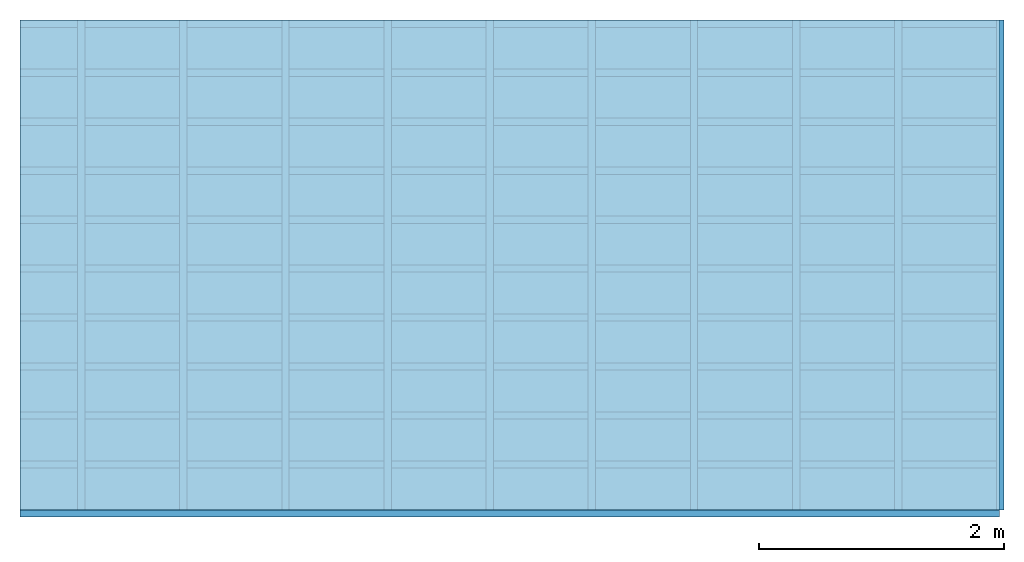
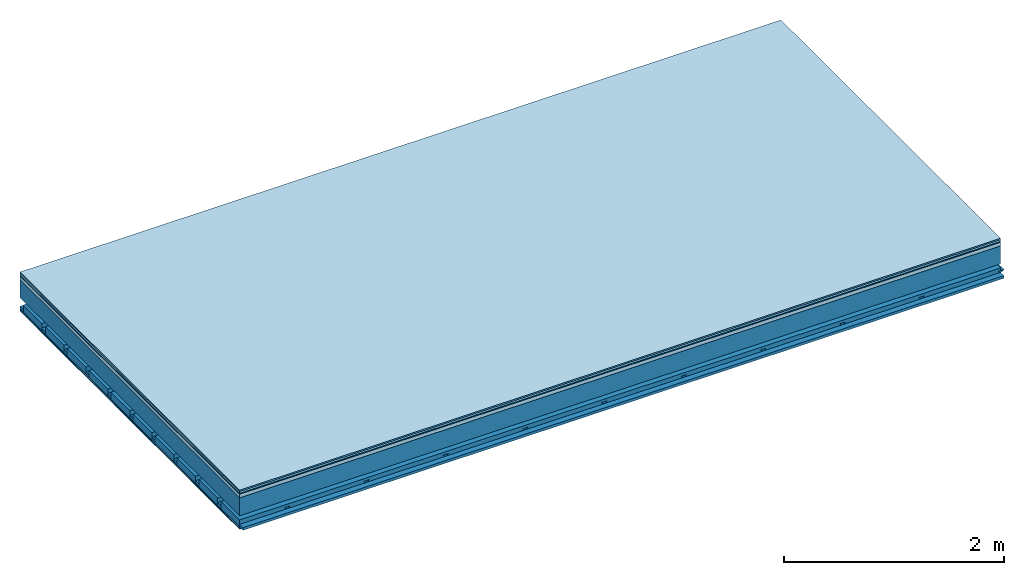
# One storey: 7 plates, 4 members, 1 element without a shape of its own.
"""IFC4 building model written with IfcOpenShell, lengths in metres."""

from ifc_helpers import new_model, si_unit, derived_unit, direction, frame, frame_2d, origin, origin_with_axes, place, context, project, spatial, polyline, rectangle, outline, extrude, material, layer, layer_set, type_object, element, aggregate, save


model = new_model("IFC4")

# Units and contexts
plan_context = context("Plan", 3, precision=1e-05, world=origin(), true_north=direction((0.0, 1.0)))
model_context = context("Model", 3, precision=1e-05, world=origin(), true_north=direction((0.0, 1.0)))
ifc_project = project(units=[si_unit("LENGTHUNIT", "METRE"), derived_unit("SOUNDPRESSUREUNIT", [(si_unit("PRESSUREUNIT", "PASCAL", prefix="MICRO"), 0)]), si_unit("ENERGYUNIT", "JOULE", prefix="MEGA"), si_unit("MASSUNIT", "GRAM", prefix="KILO"), derived_unit("THERMALTRANSMITTANCEUNIT", [(si_unit("POWERUNIT", "WATT"), 1), (si_unit("AREAUNIT", "SQUARE_METRE"), -1), (si_unit("THERMODYNAMICTEMPERATUREUNIT", "KELVIN"), -1)]), derived_unit("AREADENSITYUNIT", [(si_unit("MASSUNIT", "GRAM", prefix="KILO"), 1), (si_unit("AREAUNIT", "SQUARE_METRE"), -1)]), derived_unit("USERDEFINED", [(si_unit("ENERGYUNIT", "JOULE", prefix="MEGA"), 1), (si_unit("AREAUNIT", "SQUARE_METRE"), -1)])], contexts=[plan_context, model_context])

# Site, building, storey
site = spatial("IfcSite", under=ifc_project)
building_placement = place(None, origin())
building = spatial("IfcBuilding", under=site, at=building_placement)
storey_placement = place(building_placement, origin())
storey = spatial("IfcBuildingStorey", under=building, at=storey_placement)

# Slab, members, plates
ifc_material_1 = material(Category="11.013")
ifc_layer_1 = layer(ifc_material_1, 0.015, Name="Flooring")
ifc_material_2 = material(Category="03.007")
ifc_layer_2 = layer(ifc_material_2, 0.02, Name="On-material")
ifc_material_3 = material(Name="Wood fiber generic product", Category="10.009")
ifc_layer_3 = layer(ifc_material_3, 0.01, Name="Impact sound insulation")
ifc_material_4 = material(Name="Concrete panels", Category="02.007")
ifc_layer_4 = layer(ifc_material_4, 0.04, Name="on Supporting structure")
ifc_material_5 = material(Name="no composite action")
ifc_layer_5 = layer(ifc_material_5, 0.0, Name="Bond")
ifc_layer_6 = layer(None, 0.2, Name="Supporting structure")
ifc_layer_7 = layer(ifc_material_5, 0.0, Name="Bond")
ifc_layer_8 = layer(None, 0.095, Name="Coupling")
ifc_layer_9 = layer(None, 0.03, Name="Battens / profiles")
ifc_material_6 = material(Name="Plasterboard type A", Category="03.008")
ifc_layer_10 = layer(ifc_material_6, 0.0125, Name="Ceiling covering 1st layer")
ifc_layer_11 = layer(ifc_material_6, 0.0125, Name="Ceiling covering layer 2")
ifc_material_7 = material(Category="04.001")
ifc_layer_12 = layer(ifc_material_7, 0.003, Name="Surface / treatment")
ifc_layer_set = layer_set([ifc_layer_1, ifc_layer_2, ifc_layer_3, ifc_layer_4, ifc_layer_5, ifc_layer_6, ifc_layer_7, ifc_layer_8, ifc_layer_9, ifc_layer_10, ifc_layer_11, ifc_layer_12])
slab_type = type_object("IfcSlabType", Name="A2136", PredefinedType="NOTDEFINED", material=ifc_layer_set)
slab_placement = place(None, frame((0.0, 0.0, 0.0), z_axis=(0.0, 0.0, -1.0), x_axis=(1.0, 0.0, 0.0)))
slab = element("IfcSlab", 1, at=slab_placement, inside=storey, type_object=slab_type, material=ifc_layer_set, Name="Slab #1")
ifc_material_8 = material(Name="Solid timber panel")
member_1_placement = place(slab_placement, origin())
member_1 = element("IfcMember", 2, at=member_1_placement, material=ifc_material_8, Name="Supporting structure", context=plan_context, shape_type="SweptSolid", body=[
    extrude(rectangle(XDim=1.0, YDim=0.2, at=frame_2d((0.5, 0.1), x_axis=(1.0, 0.0))), frame((0.0, 4.0, 0.085), z_axis=(0.0, -1.0, 0.0), x_axis=(1.0, 0.0, 0.0)), (0.0, 0.0, 1.0), 4.0),
    extrude(rectangle(XDim=1.0, YDim=0.2, at=frame_2d((0.5, 0.1), x_axis=(1.0, 0.0))), frame((1.0, 4.0, 0.085), z_axis=(0.0, -1.0, 0.0), x_axis=(1.0, 0.0, 0.0)), (0.0, 0.0, 1.0), 4.0),
    extrude(rectangle(XDim=1.0, YDim=0.2, at=frame_2d((0.5, 0.1), x_axis=(1.0, 0.0))), frame((2.0, 4.0, 0.085), z_axis=(0.0, -1.0, 0.0), x_axis=(1.0, 0.0, 0.0)), (0.0, 0.0, 1.0), 4.0),
    extrude(rectangle(XDim=1.0, YDim=0.2, at=frame_2d((0.5, 0.1), x_axis=(1.0, 0.0))), frame((3.0, 4.0, 0.085), z_axis=(0.0, -1.0, 0.0), x_axis=(1.0, 0.0, 0.0)), (0.0, 0.0, 1.0), 4.0),
    extrude(rectangle(XDim=1.0, YDim=0.2, at=frame_2d((0.5, 0.1), x_axis=(1.0, 0.0))), frame((4.0, 4.0, 0.085), z_axis=(0.0, -1.0, 0.0), x_axis=(1.0, 0.0, 0.0)), (0.0, 0.0, 1.0), 4.0),
    extrude(rectangle(XDim=1.0, YDim=0.2, at=frame_2d((0.5, 0.1), x_axis=(1.0, 0.0))), frame((5.0, 4.0, 0.085), z_axis=(0.0, -1.0, 0.0), x_axis=(1.0, 0.0, 0.0)), (0.0, 0.0, 1.0), 4.0),
    extrude(rectangle(XDim=1.0, YDim=0.2, at=frame_2d((0.5, 0.1), x_axis=(1.0, 0.0))), frame((6.0, 4.0, 0.085), z_axis=(0.0, -1.0, 0.0), x_axis=(1.0, 0.0, 0.0)), (0.0, 0.0, 1.0), 4.0),
    extrude(rectangle(XDim=1.0, YDim=0.2, at=frame_2d((0.5, 0.1), x_axis=(1.0, 0.0))), frame((7.0, 4.0, 0.085), z_axis=(0.0, -1.0, 0.0), x_axis=(1.0, 0.0, 0.0)), (0.0, 0.0, 1.0), 4.0),
])
ifc_material_9 = material()
member_2_placement = place(slab_placement, origin())
member_2 = element("IfcMember", 3, at=member_2_placement, material=ifc_material_9, Name="Coupling", context=plan_context, shape_type="SweptSolid", body=[
    extrude(outline(polyline([(0.0, 0.0), (0.06, 0.0), (0.04, 0.02), (0.02, 0.02), (0.0, 0.0)])), frame((0.47, 4.0, 0.36), z_axis=(0.0, -1.0, 0.0), x_axis=(1.0, 0.0, 0.0)), (0.0, 0.0, 1.0), 4.0),
    extrude(outline(polyline([(0.0, 0.0), (0.06, 0.0), (0.04, 0.02), (0.02, 0.02), (0.0, 0.0)])), frame((1.304, 4.0, 0.36), z_axis=(0.0, -1.0, 0.0), x_axis=(1.0, 0.0, 0.0)), (0.0, 0.0, 1.0), 4.0),
    extrude(outline(polyline([(0.0, 0.0), (0.06, 0.0), (0.04, 0.02), (0.02, 0.02), (0.0, 0.0)])), frame((2.138, 4.0, 0.36), z_axis=(0.0, -1.0, 0.0), x_axis=(1.0, 0.0, 0.0)), (0.0, 0.0, 1.0), 4.0),
    extrude(outline(polyline([(0.0, 0.0), (0.06, 0.0), (0.04, 0.02), (0.02, 0.02), (0.0, 0.0)])), frame((2.972, 4.0, 0.36), z_axis=(0.0, -1.0, 0.0), x_axis=(1.0, 0.0, 0.0)), (0.0, 0.0, 1.0), 4.0),
    extrude(outline(polyline([(0.0, 0.0), (0.06, 0.0), (0.04, 0.02), (0.02, 0.02), (0.0, 0.0)])), frame((3.806, 4.0, 0.36), z_axis=(0.0, -1.0, 0.0), x_axis=(1.0, 0.0, 0.0)), (0.0, 0.0, 1.0), 4.0),
    extrude(outline(polyline([(0.0, 0.0), (0.06, 0.0), (0.04, 0.02), (0.02, 0.02), (0.0, 0.0)])), frame((4.64, 4.0, 0.36), z_axis=(0.0, -1.0, 0.0), x_axis=(1.0, 0.0, 0.0)), (0.0, 0.0, 1.0), 4.0),
    extrude(outline(polyline([(0.0, 0.0), (0.06, 0.0), (0.04, 0.02), (0.02, 0.02), (0.0, 0.0)])), frame((5.474, 4.0, 0.36), z_axis=(0.0, -1.0, 0.0), x_axis=(1.0, 0.0, 0.0)), (0.0, 0.0, 1.0), 4.0),
    extrude(outline(polyline([(0.0, 0.0), (0.06, 0.0), (0.04, 0.02), (0.02, 0.02), (0.0, 0.0)])), frame((6.308, 4.0, 0.36), z_axis=(0.0, -1.0, 0.0), x_axis=(1.0, 0.0, 0.0)), (0.0, 0.0, 1.0), 4.0),
    extrude(outline(polyline([(0.0, 0.0), (0.06, 0.0), (0.04, 0.02), (0.02, 0.02), (0.0, 0.0)])), frame((7.142, 4.0, 0.36), z_axis=(0.0, -1.0, 0.0), x_axis=(1.0, 0.0, 0.0)), (0.0, 0.0, 1.0), 4.0),
    extrude(outline(polyline([(0.0, 0.0), (0.06, 0.0), (0.04, 0.02), (0.02, 0.02), (0.0, 0.0)])), frame((7.976, 4.0, 0.36), z_axis=(0.0, -1.0, 0.0), x_axis=(1.0, 0.0, 0.0)), (0.0, 0.0, 1.0), 4.0),
])
member_3_placement = place(slab_placement, origin())
member_3 = element("IfcMember", 4, at=member_3_placement, material=ifc_material_9, Name="Battens / profiles", context=plan_context, shape_type="SweptSolid", body=[
    extrude(rectangle(XDim=0.06, YDim=0.03, at=frame_2d((0.03, 0.015), x_axis=(1.0, 0.0))), frame((0.0, 0.0, 0.38), z_axis=(1.0, 0.0, 0.0), x_axis=(0.0, 1.0, 0.0)), (0.0, 0.0, 1.0), 8.0),
    extrude(rectangle(XDim=0.06, YDim=0.03, at=frame_2d((0.03, 0.015), x_axis=(1.0, 0.0))), frame((0.0, 0.4, 0.38), z_axis=(1.0, 0.0, 0.0), x_axis=(0.0, 1.0, 0.0)), (0.0, 0.0, 1.0), 8.0),
    extrude(rectangle(XDim=0.06, YDim=0.03, at=frame_2d((0.03, 0.015), x_axis=(1.0, 0.0))), frame((0.0, 0.8, 0.38), z_axis=(1.0, 0.0, 0.0), x_axis=(0.0, 1.0, 0.0)), (0.0, 0.0, 1.0), 8.0),
    extrude(rectangle(XDim=0.06, YDim=0.03, at=frame_2d((0.03, 0.015), x_axis=(1.0, 0.0))), frame((0.0, 1.2, 0.38), z_axis=(1.0, 0.0, 0.0), x_axis=(0.0, 1.0, 0.0)), (0.0, 0.0, 1.0), 8.0),
    extrude(rectangle(XDim=0.06, YDim=0.03, at=frame_2d((0.03, 0.015), x_axis=(1.0, 0.0))), frame((0.0, 1.6, 0.38), z_axis=(1.0, 0.0, 0.0), x_axis=(0.0, 1.0, 0.0)), (0.0, 0.0, 1.0), 8.0),
    extrude(rectangle(XDim=0.06, YDim=0.03, at=frame_2d((0.03, 0.015), x_axis=(1.0, 0.0))), frame((0.0, 2.0, 0.38), z_axis=(1.0, 0.0, 0.0), x_axis=(0.0, 1.0, 0.0)), (0.0, 0.0, 1.0), 8.0),
    extrude(rectangle(XDim=0.06, YDim=0.03, at=frame_2d((0.03, 0.015), x_axis=(1.0, 0.0))), frame((0.0, 2.4, 0.38), z_axis=(1.0, 0.0, 0.0), x_axis=(0.0, 1.0, 0.0)), (0.0, 0.0, 1.0), 8.0),
    extrude(rectangle(XDim=0.06, YDim=0.03, at=frame_2d((0.03, 0.015), x_axis=(1.0, 0.0))), frame((0.0, 2.8, 0.38), z_axis=(1.0, 0.0, 0.0), x_axis=(0.0, 1.0, 0.0)), (0.0, 0.0, 1.0), 8.0),
    extrude(rectangle(XDim=0.06, YDim=0.03, at=frame_2d((0.03, 0.015), x_axis=(1.0, 0.0))), frame((0.0, 3.2, 0.38), z_axis=(1.0, 0.0, 0.0), x_axis=(0.0, 1.0, 0.0)), (0.0, 0.0, 1.0), 8.0),
    extrude(rectangle(XDim=0.06, YDim=0.03, at=frame_2d((0.03, 0.015), x_axis=(1.0, 0.0))), frame((0.0, 3.6, 0.38), z_axis=(1.0, 0.0, 0.0), x_axis=(0.0, 1.0, 0.0)), (0.0, 0.0, 1.0), 8.0),
    extrude(rectangle(XDim=0.06, YDim=0.03, at=frame_2d((0.03, 0.015), x_axis=(1.0, 0.0))), frame((0.0, 4.0, 0.38), z_axis=(1.0, 0.0, 0.0), x_axis=(0.0, 1.0, 0.0)), (0.0, 0.0, 1.0), 8.0),
])
ifc_material_10 = material()
member_4_placement = place(slab_placement, origin())
member_4 = element("IfcMember", 5, at=member_4_placement, material=ifc_material_10, Name="Cavity", context=plan_context, shape_type="SweptSolid", body=[
    extrude(rectangle(XDim=0.34, YDim=0.08, at=frame_2d((0.17, 0.04), x_axis=(1.0, 0.0))), frame((0.0, 0.06, 0.33), z_axis=(1.0, 0.0, 0.0), x_axis=(0.0, 1.0, 0.0)), (0.0, 0.0, 1.0), 8.0),
    extrude(rectangle(XDim=0.34, YDim=0.08, at=frame_2d((0.17, 0.04), x_axis=(1.0, 0.0))), frame((0.0, 0.46, 0.33), z_axis=(1.0, 0.0, 0.0), x_axis=(0.0, 1.0, 0.0)), (0.0, 0.0, 1.0), 8.0),
    extrude(rectangle(XDim=0.34, YDim=0.08, at=frame_2d((0.17, 0.04), x_axis=(1.0, 0.0))), frame((0.0, 0.86, 0.33), z_axis=(1.0, 0.0, 0.0), x_axis=(0.0, 1.0, 0.0)), (0.0, 0.0, 1.0), 8.0),
    extrude(rectangle(XDim=0.34, YDim=0.08, at=frame_2d((0.17, 0.04), x_axis=(1.0, 0.0))), frame((0.0, 1.26, 0.33), z_axis=(1.0, 0.0, 0.0), x_axis=(0.0, 1.0, 0.0)), (0.0, 0.0, 1.0), 8.0),
    extrude(rectangle(XDim=0.34, YDim=0.08, at=frame_2d((0.17, 0.04), x_axis=(1.0, 0.0))), frame((0.0, 1.66, 0.33), z_axis=(1.0, 0.0, 0.0), x_axis=(0.0, 1.0, 0.0)), (0.0, 0.0, 1.0), 8.0),
    extrude(rectangle(XDim=0.34, YDim=0.08, at=frame_2d((0.17, 0.04), x_axis=(1.0, 0.0))), frame((0.0, 2.06, 0.33), z_axis=(1.0, 0.0, 0.0), x_axis=(0.0, 1.0, 0.0)), (0.0, 0.0, 1.0), 8.0),
    extrude(rectangle(XDim=0.34, YDim=0.08, at=frame_2d((0.17, 0.04), x_axis=(1.0, 0.0))), frame((0.0, 2.46, 0.33), z_axis=(1.0, 0.0, 0.0), x_axis=(0.0, 1.0, 0.0)), (0.0, 0.0, 1.0), 8.0),
    extrude(rectangle(XDim=0.34, YDim=0.08, at=frame_2d((0.17, 0.04), x_axis=(1.0, 0.0))), frame((0.0, 2.86, 0.33), z_axis=(1.0, 0.0, 0.0), x_axis=(0.0, 1.0, 0.0)), (0.0, 0.0, 1.0), 8.0),
    extrude(rectangle(XDim=0.34, YDim=0.08, at=frame_2d((0.17, 0.04), x_axis=(1.0, 0.0))), frame((0.0, 3.26, 0.33), z_axis=(1.0, 0.0, 0.0), x_axis=(0.0, 1.0, 0.0)), (0.0, 0.0, 1.0), 8.0),
    extrude(rectangle(XDim=0.34, YDim=0.08, at=frame_2d((0.17, 0.04), x_axis=(1.0, 0.0))), frame((0.0, 3.66, 0.33), z_axis=(1.0, 0.0, 0.0), x_axis=(0.0, 1.0, 0.0)), (0.0, 0.0, 1.0), 8.0),
])
plate_1_placement = place(slab_placement, origin())
plate_1 = element("IfcPlate", 6, at=plate_1_placement, material=ifc_material_1, Name="Flooring", context=plan_context, shape_type="SweptSolid", body=[
    extrude(rectangle(XDim=8.0, YDim=4.0, at=frame_2d((4.0, 2.0), x_axis=(1.0, 0.0))), origin_with_axes(), (0.0, 0.0, 1.0), 0.015),
])
plate_2_placement = place(slab_placement, origin())
plate_2 = element("IfcPlate", 7, at=plate_2_placement, material=ifc_material_2, Name="On-material", context=plan_context, shape_type="SweptSolid", body=[
    extrude(rectangle(XDim=8.0, YDim=4.0, at=frame_2d((4.0, 2.0), x_axis=(1.0, 0.0))), frame((0.0, 0.0, 0.015), z_axis=(0.0, 0.0, 1.0), x_axis=(1.0, 0.0, 0.0)), (0.0, 0.0, 1.0), 0.02),
])
plate_3_placement = place(slab_placement, origin())
plate_3 = element("IfcPlate", 8, at=plate_3_placement, material=ifc_material_3, Name="Impact sound insulation", context=plan_context, shape_type="SweptSolid", body=[
    extrude(rectangle(XDim=8.0, YDim=4.0, at=frame_2d((4.0, 2.0), x_axis=(1.0, 0.0))), frame((0.0, 0.0, 0.035), z_axis=(0.0, 0.0, 1.0), x_axis=(1.0, 0.0, 0.0)), (0.0, 0.0, 1.0), 0.01),
])
plate_4_placement = place(slab_placement, origin())
plate_4 = element("IfcPlate", 9, at=plate_4_placement, material=ifc_material_4, Name="on Supporting structure", context=plan_context, shape_type="SweptSolid", body=[
    extrude(rectangle(XDim=8.0, YDim=4.0, at=frame_2d((4.0, 2.0), x_axis=(1.0, 0.0))), frame((0.0, 0.0, 0.045), z_axis=(0.0, 0.0, 1.0), x_axis=(1.0, 0.0, 0.0)), (0.0, 0.0, 1.0), 0.04),
])
plate_5_placement = place(slab_placement, origin())
plate_5 = element("IfcPlate", 10, at=plate_5_placement, material=ifc_material_6, Name="Ceiling covering 1st layer", context=plan_context, shape_type="SweptSolid", body=[
    extrude(rectangle(XDim=8.0, YDim=4.0, at=frame_2d((4.0, 2.0), x_axis=(1.0, 0.0))), frame((0.0, 0.0, 0.41), z_axis=(0.0, 0.0, 1.0), x_axis=(1.0, 0.0, 0.0)), (0.0, 0.0, 1.0), 0.0125),
])
plate_6_placement = place(slab_placement, origin())
plate_6 = element("IfcPlate", 11, at=plate_6_placement, material=ifc_material_6, Name="Ceiling covering layer 2", context=plan_context, shape_type="SweptSolid", body=[
    extrude(rectangle(XDim=8.0, YDim=4.0, at=frame_2d((4.0, 2.0), x_axis=(1.0, 0.0))), frame((0.0, 0.0, 0.4225), z_axis=(0.0, 0.0, 1.0), x_axis=(1.0, 0.0, 0.0)), (0.0, 0.0, 1.0), 0.0125),
])
plate_7_placement = place(slab_placement, origin())
plate_7 = element("IfcPlate", 12, at=plate_7_placement, material=ifc_material_7, Name="Surface / treatment", context=plan_context, shape_type="SweptSolid", body=[
    extrude(rectangle(XDim=8.0, YDim=4.0, at=frame_2d((4.0, 2.0), x_axis=(1.0, 0.0))), frame((0.0, 0.0, 0.435), z_axis=(0.0, 0.0, 1.0), x_axis=(1.0, 0.0, 0.0)), (0.0, 0.0, 1.0), 0.003),
])
aggregate(slab, [plate_1, plate_2, plate_3, plate_4, member_1, member_2, member_3, member_4, plate_5, plate_6, plate_7])

save(model, "model.ifc")
